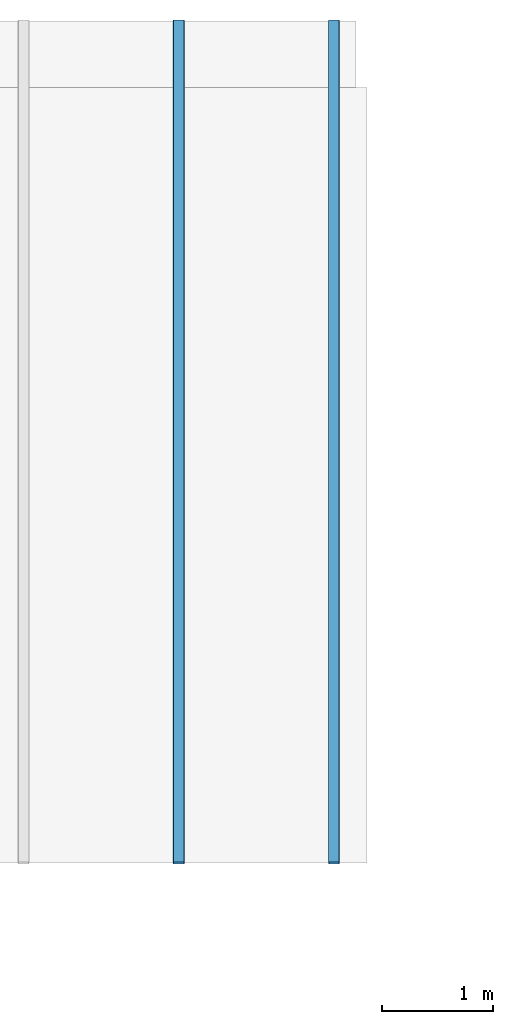
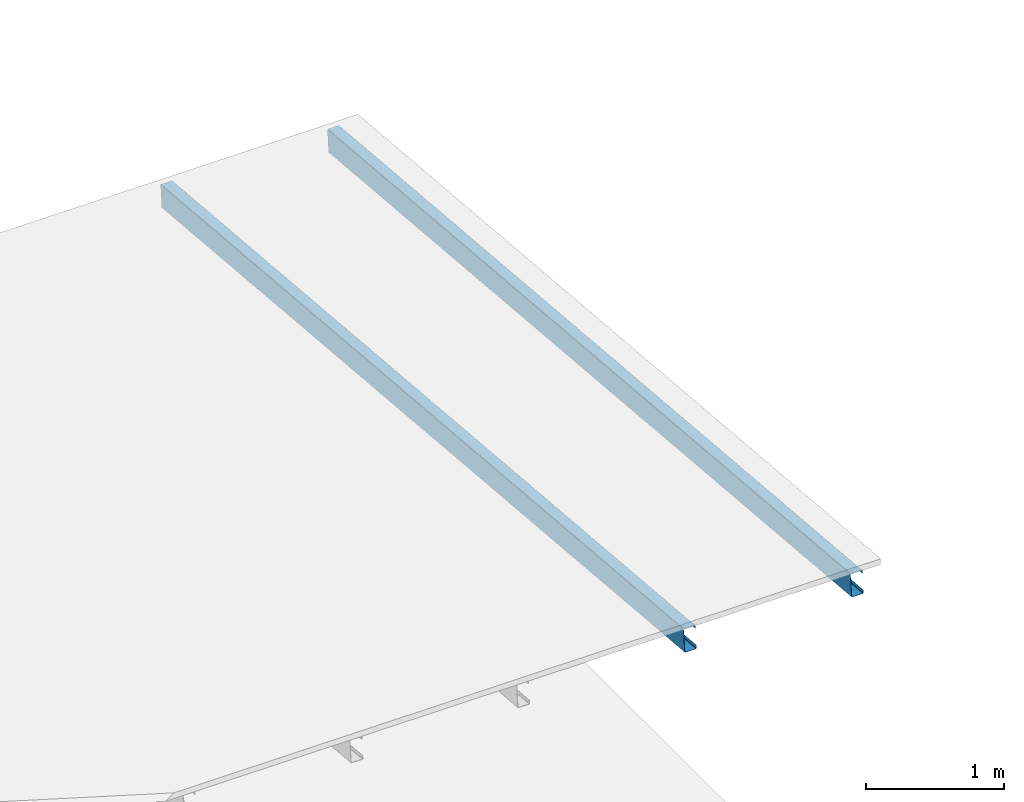
# One storey, part 4 of 8: 2 beams.
"""IFC4 building model written with IfcOpenShell, lengths in metres."""

from ifc_helpers import new_model, si_unit, frame, origin_with_axes, origin_2d_with_axis, place, context, subcontext, project, spatial, c_section, extrude, material, material_profile, profile_set, profile_usage, type_object, element, save


model = new_model("IFC4")

# Units and contexts
model_context = context("Model", 3, precision=1e-05, world=origin_with_axes())
plan_context = context("Plan", 2, precision=1e-05, world=origin_2d_with_axis())
body_context = subcontext(model_context, "Body", "Model", "MODEL_VIEW")
ifc_project = project(units=[si_unit("VOLUMEUNIT", "CUBIC_METRE"), si_unit("LENGTHUNIT", "METRE"), si_unit("AREAUNIT", "SQUARE_METRE")], contexts=[model_context, plan_context])

# Site, building, storey
site_placement = place(None, origin_with_axes())
site = spatial("IfcSite", under=ifc_project, at=site_placement)
building_placement = place(site_placement, origin_with_axes())
building = spatial("IfcBuilding", under=site, at=building_placement, Name="Building")
storey_placement = place(building_placement, frame((0.0, 0.0, 7.0), z_axis=(0.0, 0.0, 1.0), x_axis=(1.0, 0.0, 0.0)))
storey = spatial("IfcBuildingStorey", under=building, at=storey_placement, Name="Level 2")

# Beams
ifc_material = material()
ifc_material_profile = material_profile(ifc_material, c_section(Depth=0.2, Width=0.1, WallThickness=0.0015, Girth=0.03, InternalFilletRadius=0.005))
ifc_profile_set = profile_set([ifc_material_profile])
ifc_profile_usage_1 = profile_usage(ifc_profile_set, cardinal=5)
beam_type = type_object("IfcBeamType", Name="B2", PredefinedType="NOTDEFINED", material=ifc_profile_set)
beam_1_placement = place(storey_placement, frame((5.300001621246338, 7.5999979972839355, -4.149428844451904), z_axis=(-6.25029797028334e-08, -0.9961947034830787, 0.08715568112439352), x_axis=(0.999999999999998, -6.27417335863355e-08, 1.1715304223144732e-15)))
element("IfcBeam", 1, at=beam_1_placement, inside=storey, type_object=beam_type, material=ifc_profile_usage_1, Name="Beam", context=body_context, shape_type="SweptSolid", body=[
    extrude(c_section(Depth=0.2, Width=0.1, WallThickness=0.0015, Girth=0.03, InternalFilletRadius=0.005), origin_with_axes(), (0.0, 0.0, 1.0), 7.629030118250166),
])
ifc_profile_usage_2 = profile_usage(ifc_profile_set, cardinal=5)
beam_2_placement = place(storey_placement, frame((6.700001239776611, 7.599997520446777, -4.149428844451904), z_axis=(-6.25029797028334e-08, -0.9961947034830787, 0.08715568112439352), x_axis=(0.999999999999998, -6.27417335863355e-08, 1.1715304223144732e-15)))
element("IfcBeam", 2, at=beam_2_placement, inside=storey, type_object=beam_type, material=ifc_profile_usage_2, Name="Beam", context=body_context, shape_type="SweptSolid", body=[
    extrude(c_section(Depth=0.2, Width=0.1, WallThickness=0.0015, Girth=0.03, InternalFilletRadius=0.005), origin_with_axes(), (0.0, 0.0, 1.0), 7.629030118250166),
])

save(model, "model.ifc")
